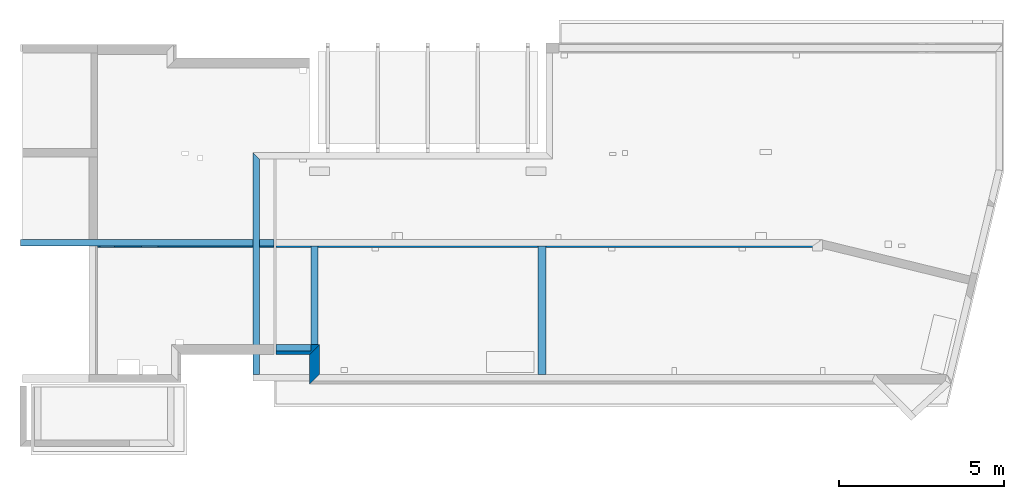
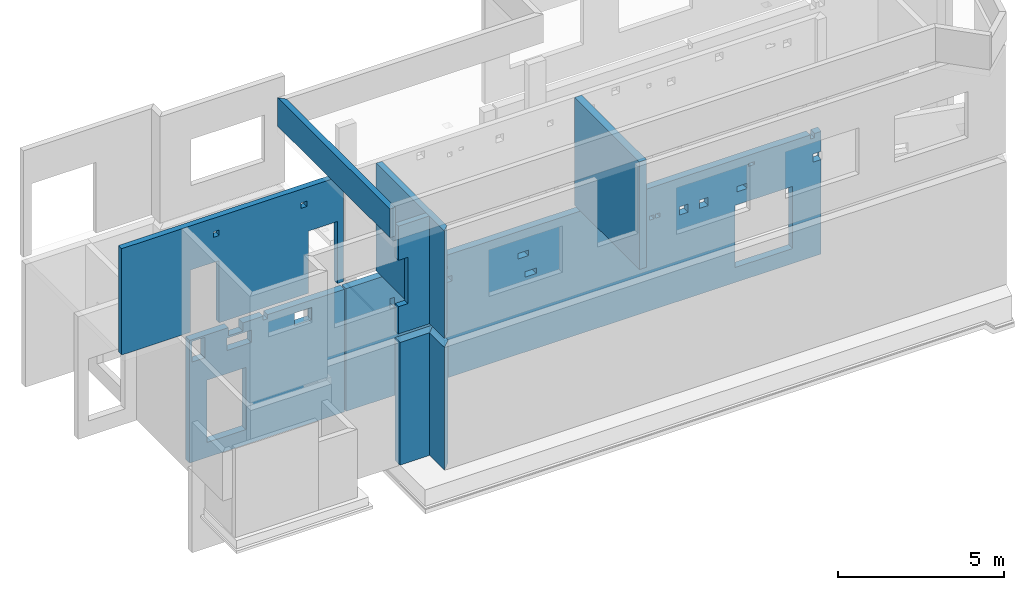
# One storey, part 2 of 7: 9 walls, 30 openings.
"""IFC2X3 building model written with IfcOpenShell, lengths in millimetres."""

from ifc_helpers import new_model, entity, si_unit, converted_unit, derived_unit, money_unit, direction, frame, frame_2d, origin_with_axes, place, context, subcontext, project, spatial, polyline, rectangle, outline, extrude, faceted_brep, material, layer, layer_set, layer_usage, type_object, element, save


model = new_model("IFC2X3")

# Units and contexts
model_context = context("Model", 3, precision=1e-05, world=origin_with_axes(), true_north=direction((0.0, 1.0)))
body_context = subcontext(model_context, "Body", "Model", "MODEL_VIEW", scale=1.0)
ifc_project = project(units=[si_unit("LENGTHUNIT", "METRE", prefix="MILLI"), si_unit("AREAUNIT", "SQUARE_METRE"), si_unit("VOLUMEUNIT", "CUBIC_METRE"), si_unit("ABSORBEDDOSEUNIT", "GRAY"), si_unit("AMOUNTOFSUBSTANCEUNIT", "MOLE"), si_unit("DOSEEQUIVALENTUNIT", "SIEVERT"), si_unit("ELECTRICCAPACITANCEUNIT", "FARAD"), si_unit("ELECTRICCHARGEUNIT", "COULOMB"), si_unit("ELECTRICCONDUCTANCEUNIT", "SIEMENS"), si_unit("ELECTRICCURRENTUNIT", "AMPERE"), si_unit("ELECTRICRESISTANCEUNIT", "OHM"), si_unit("ELECTRICVOLTAGEUNIT", "VOLT"), si_unit("ENERGYUNIT", "JOULE"), si_unit("FORCEUNIT", "NEWTON"), si_unit("FREQUENCYUNIT", "HERTZ"), si_unit("ILLUMINANCEUNIT", "LUX"), si_unit("INDUCTANCEUNIT", "HENRY"), si_unit("LUMINOUSFLUXUNIT", "LUMEN"), si_unit("LUMINOUSINTENSITYUNIT", "CANDELA"), si_unit("MAGNETICFLUXDENSITYUNIT", "TESLA"), si_unit("MAGNETICFLUXUNIT", "WEBER"), si_unit("MASSUNIT", "GRAM"), converted_unit("PLANEANGLEUNIT", "degree", entity("IfcReal", 0.0174532925199433), si_unit("PLANEANGLEUNIT", "RADIAN"), dimensions=[0, 0, 0, 0, 0, 0, 0]), si_unit("POWERUNIT", "WATT"), si_unit("PRESSUREUNIT", "PASCAL"), si_unit("RADIOACTIVITYUNIT", "BECQUEREL"), si_unit("SOLIDANGLEUNIT", "STERADIAN"), si_unit("THERMODYNAMICTEMPERATUREUNIT", "KELVIN"), si_unit("TIMEUNIT", "SECOND"), derived_unit("ACCELERATIONUNIT", [(si_unit("LENGTHUNIT", "METRE", prefix="MILLI"), 1), (si_unit("TIMEUNIT", "SECOND"), -2)]), derived_unit("ANGULARVELOCITYUNIT", [(converted_unit("PLANEANGLEUNIT", "degree", entity("IfcReal", 0.0174532925199433), si_unit("PLANEANGLEUNIT", "RADIAN"), dimensions=[0, 0, 0, 0, 0, 0, 0]), 1), (si_unit("TIMEUNIT", "SECOND"), -1)]), derived_unit("CURVATUREUNIT", [(converted_unit("PLANEANGLEUNIT", "degree", entity("IfcReal", 0.0174532925199433), si_unit("PLANEANGLEUNIT", "RADIAN"), dimensions=[0, 0, 0, 0, 0, 0, 0]), 1), (si_unit("LENGTHUNIT", "METRE", prefix="MILLI"), -1)]), derived_unit("DYNAMICVISCOSITYUNIT", [(si_unit("PRESSUREUNIT", "PASCAL"), 1), (si_unit("TIMEUNIT", "SECOND"), 1)]), derived_unit("HEATFLUXDENSITYUNIT", [(si_unit("POWERUNIT", "WATT"), 1), (si_unit("LENGTHUNIT", "METRE", prefix="MILLI"), -2)]), derived_unit("HEATINGVALUEUNIT", [(si_unit("ENERGYUNIT", "JOULE"), 1), (si_unit("MASSUNIT", "GRAM"), -1)]), derived_unit("INTEGERCOUNTRATEUNIT", [(si_unit("TIMEUNIT", "SECOND"), -1)]), derived_unit("IONCONCENTRATIONUNIT", [(si_unit("MASSUNIT", "GRAM"), 1), (si_unit("VOLUMEUNIT", "CUBIC_METRE"), -1)]), derived_unit("ISOTHERMALMOISTURECAPACITYUNIT", [(si_unit("VOLUMEUNIT", "CUBIC_METRE"), 1), (si_unit("MASSUNIT", "GRAM"), -1)]), derived_unit("KINEMATICVISCOSITYUNIT", [(si_unit("AREAUNIT", "SQUARE_METRE"), 1), (si_unit("TIMEUNIT", "SECOND"), -1)]), derived_unit("LINEARFORCEUNIT", [(si_unit("FORCEUNIT", "NEWTON"), 1), (si_unit("LENGTHUNIT", "METRE", prefix="MILLI"), -1)]), derived_unit("LINEARMOMENTUNIT", [(si_unit("FORCEUNIT", "NEWTON"), 1), (si_unit("LENGTHUNIT", "METRE", prefix="MILLI"), -1)]), derived_unit("LINEARSTIFFNESSUNIT", [(si_unit("FORCEUNIT", "NEWTON"), 1), (si_unit("LENGTHUNIT", "METRE", prefix="MILLI"), -1)]), derived_unit("LINEARVELOCITYUNIT", [(si_unit("LENGTHUNIT", "METRE", prefix="MILLI"), 1), (si_unit("TIMEUNIT", "SECOND"), -1)]), derived_unit("LUMINOUSINTENSITYDISTRIBUTIONUNIT", [(si_unit("LUMINOUSINTENSITYUNIT", "CANDELA"), 1), (si_unit("LUMINOUSFLUXUNIT", "LUMEN"), -1)]), derived_unit("MASSDENSITYUNIT", [(si_unit("MASSUNIT", "GRAM"), 1), (si_unit("VOLUMEUNIT", "CUBIC_METRE"), -1)]), derived_unit("MASSFLOWRATEUNIT", [(si_unit("MASSUNIT", "GRAM"), 1), (si_unit("TIMEUNIT", "SECOND"), -1)]), derived_unit("MASSPERLENGTHUNIT", [(si_unit("MASSUNIT", "GRAM"), 1), (si_unit("LENGTHUNIT", "METRE", prefix="MILLI"), -1)]), derived_unit("MODULUSOFELASTICITYUNIT", [(si_unit("FORCEUNIT", "NEWTON"), 1), (si_unit("AREAUNIT", "SQUARE_METRE"), -1)]), derived_unit("MODULUSOFLINEARSUBGRADEREACTIONUNIT", [(si_unit("FORCEUNIT", "NEWTON"), 1), (si_unit("LENGTHUNIT", "METRE", prefix="MILLI"), -2)]), derived_unit("MODULUSOFROTATIONALSUBGRADEREACTIONUNIT", [(si_unit("FORCEUNIT", "NEWTON"), 1), (si_unit("LENGTHUNIT", "METRE", prefix="MILLI"), 1)]), derived_unit("MODULUSOFSUBGRADEREACTIONUNIT", [(si_unit("FORCEUNIT", "NEWTON"), 1), (si_unit("VOLUMEUNIT", "CUBIC_METRE"), -1)]), derived_unit("MOISTUREDIFFUSIVITYUNIT", [(si_unit("VOLUMEUNIT", "CUBIC_METRE"), 1), (si_unit("TIMEUNIT", "SECOND"), -1)]), derived_unit("MOLECULARWEIGHTUNIT", [(si_unit("MASSUNIT", "GRAM"), 1), (si_unit("AMOUNTOFSUBSTANCEUNIT", "MOLE"), -1)]), derived_unit("PLANARFORCEUNIT", [(si_unit("FORCEUNIT", "NEWTON"), 1), (si_unit("LENGTHUNIT", "METRE", prefix="MILLI"), -2)]), derived_unit("ROTATIONALFREQUENCYUNIT", [(si_unit("TIMEUNIT", "SECOND"), -1)]), derived_unit("ROTATIONALMASSUNIT", [(si_unit("MASSUNIT", "GRAM"), 1), (si_unit("LENGTHUNIT", "METRE", prefix="MILLI"), 2)]), derived_unit("ROTATIONALSTIFFNESSUNIT", [(si_unit("FORCEUNIT", "NEWTON"), 1), (si_unit("LENGTHUNIT", "METRE", prefix="MILLI"), 1), (converted_unit("PLANEANGLEUNIT", "degree", entity("IfcReal", 0.0174532925199433), si_unit("PLANEANGLEUNIT", "RADIAN"), dimensions=[0, 0, 0, 0, 0, 0, 0]), -1)]), derived_unit("SECTIONAREAINTEGRALUNIT", [(si_unit("LENGTHUNIT", "METRE", prefix="MILLI"), 5)]), derived_unit("SECTIONMODULUSUNIT", [(si_unit("LENGTHUNIT", "METRE", prefix="MILLI"), 3)]), derived_unit("SHEARMODULUSUNIT", [(si_unit("FORCEUNIT", "NEWTON"), 1), (si_unit("AREAUNIT", "SQUARE_METRE"), -1)]), derived_unit("SOUNDPOWERUNIT", [(si_unit("ENERGYUNIT", "JOULE"), 1), (si_unit("TIMEUNIT", "SECOND"), -1)]), derived_unit("SPECIFICHEATCAPACITYUNIT", [(si_unit("FORCEUNIT", "NEWTON"), 1), (si_unit("MASSUNIT", "GRAM"), -1), (si_unit("THERMODYNAMICTEMPERATUREUNIT", "KELVIN"), -1)]), derived_unit("TEMPERATUREGRADIENTUNIT", [(si_unit("THERMODYNAMICTEMPERATUREUNIT", "KELVIN"), 1), (si_unit("LENGTHUNIT", "METRE", prefix="MILLI"), -1)]), derived_unit("THERMALADMITTANCEUNIT", [(si_unit("POWERUNIT", "WATT"), 1), (si_unit("AREAUNIT", "SQUARE_METRE"), -1), (si_unit("THERMODYNAMICTEMPERATUREUNIT", "KELVIN"), -1)]), derived_unit("THERMALCONDUCTANCEUNIT", [(si_unit("POWERUNIT", "WATT"), 1), (si_unit("LENGTHUNIT", "METRE", prefix="MILLI"), -1), (si_unit("THERMODYNAMICTEMPERATUREUNIT", "KELVIN"), -1)]), derived_unit("THERMALEXPANSIONCOEFFICIENTUNIT", [(si_unit("THERMODYNAMICTEMPERATUREUNIT", "KELVIN"), -1)]), derived_unit("THERMALRESISTANCEUNIT", [(si_unit("AREAUNIT", "SQUARE_METRE"), 1), (si_unit("POWERUNIT", "WATT"), -1)]), derived_unit("THERMALTRANSMITTANCEUNIT", [(si_unit("POWERUNIT", "WATT"), 1), (si_unit("AREAUNIT", "SQUARE_METRE"), -1), (si_unit("THERMODYNAMICTEMPERATUREUNIT", "KELVIN"), -1)]), derived_unit("TORQUEUNIT", [(si_unit("FORCEUNIT", "NEWTON"), 1), (si_unit("LENGTHUNIT", "METRE", prefix="MILLI"), 1)]), derived_unit("VAPORPERMEABILITYUNIT", [(si_unit("MASSUNIT", "GRAM"), 1), (si_unit("TIMEUNIT", "SECOND"), -1)]), derived_unit("VOLUMETRICFLOWRATEUNIT", [(si_unit("VOLUMEUNIT", "CUBIC_METRE"), 1), (si_unit("TIMEUNIT", "SECOND"), -1)]), derived_unit("WARPINGCONSTANTUNIT", [(si_unit("LENGTHUNIT", "METRE", prefix="MILLI"), 6)]), derived_unit("WARPINGMOMENTUNIT", [(si_unit("FORCEUNIT", "NEWTON"), 1), (si_unit("LENGTHUNIT", "METRE", prefix="MILLI"), 2)]), money_unit("USD")], contexts=[model_context])

# Site, building, storey
site_placement = place(None, origin_with_axes())
site = spatial("IfcSite", under=ifc_project, at=site_placement, CompositionType="ELEMENT")
building_placement = place(site_placement, origin_with_axes())
building = spatial("IfcBuilding", under=site, at=building_placement, Name="1", CompositionType="ELEMENT")
storey_placement = place(building_placement, frame((0.0, 0.0, -4900.0), z_axis=(0.0, 0.0, 1.0), x_axis=(1.0, 0.0, 0.0)))
storey = spatial("IfcBuildingStorey", under=building, at=storey_placement, CompositionType="ELEMENT", Elevation=-4900.0)

# Wall, openings
ifc_material = material()
ifc_layer_1 = layer(ifc_material, 250.0, ventilated=False)
ifc_layer_set_1 = layer_set([ifc_layer_1])
ifc_layer_usage_1 = layer_usage(ifc_layer_set_1, "AXIS2", "POSITIVE", 0.0)
wall_type = type_object("IfcWallType", PredefinedType="NOTDEFINED")
wall_1_placement = place(storey_placement, frame((2530.0, 3850.0, 0.0), z_axis=(0.0, 0.0, 1.0), x_axis=(1.0, 0.0, 0.0)))
wall_1 = element("IfcWallStandardCase", 1, at=wall_1_placement, inside=storey, type_object=wall_type, material=ifc_layer_usage_1, context=body_context, shape_type="SweptSolid", body=[
    extrude(rectangle(XDim=5370.0, YDim=250.0, at=frame_2d((2685.0, 125.0), x_axis=(1.0, 0.0))), origin_with_axes(), (0.0, 0.0, 1.0), 4500.0),
])
opening_1_placement = place(wall_1_placement, frame((600.0, 0.0, 550.0), z_axis=(0.0, 0.0, 1.0), x_axis=(1.0, 0.0, 0.0)))
element("IfcOpeningElement", 2, at=opening_1_placement, cuts=wall_1, ObjectType="Opening", context=body_context, shape_type="SweptSolid", body=[
    extrude(rectangle(XDim=2280.0, YDim=1350.0, at=frame_2d((-675.0, 1140.0), x_axis=(0.0, -1.0))), frame((0.0, 0.0, 0.0), z_axis=(0.0, 1.0, 0.0), x_axis=(-1.0, 0.0, 0.0)), (0.0, 0.0, 1.0), 250.0),
])
opening_2_placement = place(wall_1_placement, frame((75.0, 0.0, 3680.0), z_axis=(0.0, 0.0, 1.0), x_axis=(1.0, 0.0, 0.0)))
element("IfcOpeningElement", 3, at=opening_2_placement, cuts=wall_1, ObjectType="Opening", context=body_context, shape_type="SweptSolid", body=[
    extrude(rectangle(XDim=750.0, YDim=450.0, at=frame_2d((-225.0, 375.0), x_axis=(0.0, -1.0))), frame((0.0, 0.0, 0.0), z_axis=(0.0, 1.0, 0.0), x_axis=(-1.0, 0.0, 0.0)), (0.0, 0.0, 1.0), 250.0),
])
opening_3_placement = place(wall_1_placement, frame((1290.0, 0.0, 3680.0), z_axis=(0.0, 0.0, 1.0), x_axis=(1.0, 0.0, 0.0)))
element("IfcOpeningElement", 4, at=opening_3_placement, cuts=wall_1, ObjectType="Opening", context=body_context, shape_type="SweptSolid", body=[
    extrude(rectangle(XDim=450.0, YDim=850.0, at=frame_2d((-425.0, 225.0), x_axis=(0.0, -1.0))), frame((0.0, 0.0, 0.0), z_axis=(0.0, 1.0, 0.0), x_axis=(-1.0, 0.0, 0.0)), (0.0, 0.0, 1.0), 250.0),
])
opening_4_placement = place(wall_1_placement, frame((1340.0, 0.0, 4200.0), z_axis=(0.0, 0.0, 1.0), x_axis=(1.0, 0.0, 0.0)))
element("IfcOpeningElement", 5, at=opening_4_placement, cuts=wall_1, ObjectType="Opening", context=body_context, shape_type="SweptSolid", body=[
    extrude(rectangle(XDim=300.0, YDim=500.0, at=frame_2d((-250.0, 150.0), x_axis=(0.0, -1.0))), frame((0.0, 0.0, 0.0), z_axis=(0.0, 1.0, 0.0), x_axis=(-1.0, 0.0, 0.0)), (0.0, 0.0, 1.0), 250.0),
])
opening_5_placement = place(wall_1_placement, frame((2550.000072, 0.0, 4350.0), z_axis=(0.0, 0.0, 1.0), x_axis=(1.0, 0.0, 0.0)))
element("IfcOpeningElement", 6, at=opening_5_placement, cuts=wall_1, ObjectType="Opening", context=body_context, shape_type="SweptSolid", body=[
    extrude(rectangle(XDim=150.0, YDim=150.0, at=frame_2d((-75.0, 75.0), x_axis=(0.0, -1.0))), frame((0.0, 0.0, 0.0), z_axis=(0.0, 1.0, 0.0), x_axis=(-1.0, 0.0, 0.0)), (0.0, 0.0, 1.0), 250.0),
])
opening_6_placement = place(wall_1_placement, frame((3629.999861, 0.0, 3780.0), z_axis=(0.0, 0.0, 1.0), x_axis=(1.0, 0.0, 0.0)))
element("IfcOpeningElement", 7, at=opening_6_placement, cuts=wall_1, ObjectType="Opening", context=body_context, shape_type="SweptSolid", body=[
    extrude(rectangle(XDim=450.0, YDim=600.0, at=frame_2d((-300.0, 225.0), x_axis=(0.0, -1.0))), frame((0.0, 0.0, 0.0), z_axis=(0.0, 1.0, 0.0), x_axis=(-1.0, 0.0, 0.0)), (0.0, 0.0, 1.0), 250.0),
])

wall_2_placement = place(storey_placement, frame((7950.0, 3850.0, 0.0), z_axis=(0.0, 0.0, 1.0), x_axis=(1.0, 0.0, 0.0)))
wall_2 = element("IfcWallStandardCase", 8, at=wall_2_placement, inside=storey, type_object=wall_type, material=ifc_layer_usage_1, context=body_context, shape_type="SweptSolid", body=[
    extrude(outline(polyline([(16515.0, 250.0), (0.0, 250.0), (0.0, 0.0), (16484.990959, 0.0), (16515.0, 250.0)])), origin_with_axes(), (0.0, 0.0, 1.0), 4500.0),
])
opening_7_placement = place(wall_2_placement, frame((13495.0, 0.0, 550.0), z_axis=(0.0, 0.0, 1.0), x_axis=(1.0, 0.0, 0.0)))
element("IfcOpeningElement", 9, at=opening_7_placement, cuts=wall_2, ObjectType="Opening", context=body_context, shape_type="SweptSolid", body=[
    extrude(rectangle(XDim=2280.0, YDim=2000.0, at=frame_2d((-1000.0, 1140.0), x_axis=(0.0, -1.0))), frame((0.0, 0.0, 0.0), z_axis=(0.0, 1.0, 0.0), x_axis=(-1.0, 0.0, 0.0)), (0.0, 0.0, 1.0), 250.0),
])
opening_8_placement = place(wall_2_placement, frame((1525.0, 0.0, 3240.0), z_axis=(0.0, 0.0, 1.0), x_axis=(1.0, 0.0, 0.0)))
element("IfcOpeningElement", 10, at=opening_8_placement, cuts=wall_2, ObjectType="Opening", context=body_context, shape_type="SweptSolid", body=[
    extrude(rectangle(XDim=360.0, YDim=150.0, at=frame_2d((-75.0, 180.0), x_axis=(0.0, -1.0))), frame((0.0, 0.0, 0.0), z_axis=(0.0, 1.0, 0.0), x_axis=(-1.0, 0.0, 0.0)), (0.0, 0.0, 1.0), 250.0),
])
opening_9_placement = place(wall_2_placement, frame((3025.0, 0.0, 3500.0), z_axis=(0.0, 0.0, 1.0), x_axis=(1.0, 0.0, 0.0)))
element("IfcOpeningElement", 11, at=opening_9_placement, cuts=wall_2, ObjectType="Opening", context=body_context, shape_type="SweptSolid", body=[
    extrude(rectangle(XDim=200.0, YDim=200.0, at=frame_2d((-100.0, 100.0), x_axis=(0.0, -1.0))), frame((0.0, 0.0, 0.0), z_axis=(0.0, 1.0, 0.0), x_axis=(-1.0, 0.0, 0.0)), (0.0, 0.0, 1.0), 250.0),
])
opening_10_placement = place(wall_2_placement, frame((3475.0, 0.0, 3500.0), z_axis=(0.0, 0.0, 1.0), x_axis=(1.0, 0.0, 0.0)))
element("IfcOpeningElement", 12, at=opening_10_placement, cuts=wall_2, ObjectType="Opening", context=body_context, shape_type="SweptSolid", body=[
    extrude(rectangle(XDim=200.0, YDim=200.0, at=frame_2d((-100.0, 100.0), x_axis=(0.0, -1.0))), frame((0.0, 0.0, 0.0), z_axis=(0.0, 1.0, 0.0), x_axis=(-1.0, 0.0, 0.0)), (0.0, 0.0, 1.0), 250.0),
])
opening_11_placement = place(wall_2_placement, frame((5975.0, 0.0, 3500.0), z_axis=(0.0, 0.0, 1.0), x_axis=(1.0, 0.0, 0.0)))
element("IfcOpeningElement", 13, at=opening_11_placement, cuts=wall_2, ObjectType="Opening", context=body_context, shape_type="SweptSolid", body=[
    extrude(rectangle(XDim=200.0, YDim=350.0, at=frame_2d((-175.0, 100.0), x_axis=(0.0, -1.0))), frame((0.0, 0.0, 0.0), z_axis=(0.0, 1.0, 0.0), x_axis=(-1.0, 0.0, 0.0)), (0.0, 0.0, 1.0), 250.0),
])
opening_12_placement = place(wall_2_placement, frame((3315.0, 0.0, 4000.0), z_axis=(0.0, 0.0, 1.0), x_axis=(1.0, 0.0, 0.0)))
element("IfcOpeningElement", 14, at=opening_12_placement, cuts=wall_2, ObjectType="Opening", context=body_context, shape_type="SweptSolid", body=[
    extrude(rectangle(XDim=100.0, YDim=200.0, at=frame_2d((-100.0, 50.0), x_axis=(0.0, -1.0))), frame((0.0, 0.0, 0.0), z_axis=(0.0, 1.0, 0.0), x_axis=(-1.0, 0.0, 0.0)), (0.0, 0.0, 1.0), 250.0),
])
opening_13_placement = place(wall_2_placement, frame((6205.0, 0.0, 2750.0), z_axis=(0.0, 0.0, 1.0), x_axis=(1.0, 0.0, 0.0)))
element("IfcOpeningElement", 15, at=opening_13_placement, cuts=wall_2, ObjectType="Opening", context=body_context, shape_type="SweptSolid", body=[
    extrude(rectangle(XDim=200.0, YDim=400.0, at=frame_2d((-200.0, 100.0), x_axis=(0.0, -1.0))), frame((0.0, 0.0, 0.0), z_axis=(0.0, 1.0, 0.0), x_axis=(-1.0, 0.0, 0.0)), (0.0, 0.0, 1.0), 250.0),
])
opening_14_placement = place(wall_2_placement, frame((9635.0, 0.0, 3300.0), z_axis=(0.0, 0.0, 1.0), x_axis=(1.0, 0.0, 0.0)))
element("IfcOpeningElement", 16, at=opening_14_placement, cuts=wall_2, ObjectType="Opening", context=body_context, shape_type="SweptSolid", body=[
    extrude(rectangle(XDim=200.0, YDim=200.0, at=frame_2d((-100.0, 100.0), x_axis=(0.0, -1.0))), frame((0.0, 0.0, 0.0), z_axis=(0.0, 1.0, 0.0), x_axis=(-1.0, 0.0, 0.0)), (0.0, 0.0, 1.0), 250.0),
])
opening_15_placement = place(wall_2_placement, frame((9985.0, 0.0, 3300.0), z_axis=(0.0, 0.0, 1.0), x_axis=(1.0, 0.0, 0.0)))
element("IfcOpeningElement", 17, at=opening_15_placement, cuts=wall_2, ObjectType="Opening", context=body_context, shape_type="SweptSolid", body=[
    extrude(rectangle(XDim=200.0, YDim=200.0, at=frame_2d((-100.0, 100.0), x_axis=(0.0, -1.0))), frame((0.0, 0.0, 0.0), z_axis=(0.0, 1.0, 0.0), x_axis=(-1.0, 0.0, 0.0)), (0.0, 0.0, 1.0), 250.0),
])
opening_16_placement = place(wall_2_placement, frame((10535.0, 0.0, 3325.0), z_axis=(0.0, 0.0, 1.0), x_axis=(1.0, 0.0, 0.0)))
element("IfcOpeningElement", 18, at=opening_16_placement, cuts=wall_2, ObjectType="Opening", context=body_context, shape_type="SweptSolid", body=[
    extrude(rectangle(XDim=150.0, YDim=150.0, at=frame_2d((-75.0, 75.0), x_axis=(0.0, -1.0))), frame((0.0, 0.0, 0.0), z_axis=(0.0, 1.0, 0.0), x_axis=(-1.0, 0.0, 0.0)), (0.0, 0.0, 1.0), 250.0),
])
opening_17_placement = place(wall_2_placement, frame((10745.0, 0.0, 3325.0), z_axis=(0.0, 0.0, 1.0), x_axis=(1.0, 0.0, 0.0)))
element("IfcOpeningElement", 19, at=opening_17_placement, cuts=wall_2, ObjectType="Opening", context=body_context, shape_type="SweptSolid", body=[
    extrude(rectangle(XDim=150.0, YDim=150.0, at=frame_2d((-75.0, 75.0), x_axis=(0.0, -1.0))), frame((0.0, 0.0, 0.0), z_axis=(0.0, 1.0, 0.0), x_axis=(-1.0, 0.0, 0.0)), (0.0, 0.0, 1.0), 250.0),
])
opening_18_placement = place(wall_2_placement, frame((11565.0, 0.0, 3150.0), z_axis=(0.0, 0.0, 1.0), x_axis=(1.0, 0.0, 0.0)))
element("IfcOpeningElement", 20, at=opening_18_placement, cuts=wall_2, ObjectType="Opening", context=body_context, shape_type="SweptSolid", body=[
    extrude(rectangle(XDim=300.0, YDim=300.0, at=frame_2d((-150.0, 150.0), x_axis=(0.0, -1.0))), frame((0.0, 0.0, 0.0), z_axis=(0.0, 1.0, 0.0), x_axis=(-1.0, 0.0, 0.0)), (0.0, 0.0, 1.0), 250.0),
])
opening_19_placement = place(wall_2_placement, frame((12265.0, 0.0, 3150.0), z_axis=(0.0, 0.0, 1.0), x_axis=(1.0, 0.0, 0.0)))
element("IfcOpeningElement", 21, at=opening_19_placement, cuts=wall_2, ObjectType="Opening", context=body_context, shape_type="SweptSolid", body=[
    extrude(rectangle(XDim=300.0, YDim=300.0, at=frame_2d((-150.0, 150.0), x_axis=(0.0, -1.0))), frame((0.0, 0.0, 0.0), z_axis=(0.0, 1.0, 0.0), x_axis=(-1.0, 0.0, 0.0)), (0.0, 0.0, 1.0), 250.0),
])
opening_20_placement = place(wall_2_placement, frame((13565.0, 0.0, 3300.0), z_axis=(0.0, 0.0, 1.0), x_axis=(1.0, 0.0, 0.0)))
element("IfcOpeningElement", 22, at=opening_20_placement, cuts=wall_2, ObjectType="Opening", context=body_context, shape_type="SweptSolid", body=[
    extrude(rectangle(XDim=200.0, YDim=350.0, at=frame_2d((-175.0, 100.0), x_axis=(0.0, -1.0))), frame((0.0, 0.0, 0.0), z_axis=(0.0, 1.0, 0.0), x_axis=(-1.0, 0.0, 0.0)), (0.0, 0.0, 1.0), 250.0),
])
opening_21_placement = place(wall_2_placement, frame((16205.0, 0.0, 3465.0), z_axis=(0.0, 0.0, 1.0), x_axis=(1.0, 0.0, 0.0)))
element("IfcOpeningElement", 23, at=opening_21_placement, cuts=wall_2, ObjectType="Opening", context=body_context, shape_type="SweptSolid", body=[
    extrude(rectangle(XDim=300.0, YDim=300.0, at=frame_2d((-150.0, 150.0), x_axis=(0.0, -1.0))), frame((0.0, 0.0, 0.0), z_axis=(0.0, 1.0, 0.0), x_axis=(-1.0, 0.0, 0.0)), (0.0, 0.0, 1.0), 250.0),
])
opening_22_placement = place(wall_2_placement, frame((9549.956428, 0.0, 2950.0), z_axis=(0.0, 0.0, 1.0), x_axis=(1.0, 0.0, 0.0)))
element("IfcOpeningElement", 24, at=opening_22_placement, cuts=wall_2, ObjectType="Opening", context=body_context, shape_type="SweptSolid", body=[
    extrude(rectangle(XDim=200.0, YDim=400.0, at=frame_2d((-200.0, 100.0), x_axis=(0.0, -1.0))), frame((0.0, 0.0, 0.0), z_axis=(0.0, 1.0, 0.0), x_axis=(-1.0, 0.0, 0.0)), (0.0, 0.0, 1.0), 250.0),
])
opening_23_placement = place(wall_2_placement, frame((10079.956428, 0.0, 4100.0), z_axis=(0.0, 0.0, 1.0), x_axis=(1.0, 0.0, 0.0)))
element("IfcOpeningElement", 25, at=opening_23_placement, cuts=wall_2, ObjectType="Opening", context=body_context, shape_type="SweptSolid", body=[
    extrude(rectangle(XDim=100.0, YDim=200.0, at=frame_2d((-100.0, 50.0), x_axis=(0.0, -1.0))), frame((0.0, 0.0, 0.0), z_axis=(0.0, 1.0, 0.0), x_axis=(-1.0, 0.0, 0.0)), (0.0, 0.0, 1.0), 250.0),
])
opening_24_placement = place(wall_2_placement, frame((13965.0, 0.0, 4100.0), z_axis=(0.0, 0.0, 1.0), x_axis=(1.0, 0.0, 0.0)))
element("IfcOpeningElement", 26, at=opening_24_placement, cuts=wall_2, ObjectType="Opening", context=body_context, shape_type="SweptSolid", body=[
    extrude(rectangle(XDim=100.0, YDim=200.0, at=frame_2d((-100.0, 50.0), x_axis=(0.0, -1.0))), frame((0.0, 0.0, 0.0), z_axis=(0.0, 1.0, 0.0), x_axis=(-1.0, 0.0, 0.0)), (0.0, 0.0, 1.0), 250.0),
])
opening_25_placement = place(wall_2_placement, frame((16105.0, 0.0, 4350.0), z_axis=(0.0, 0.0, 1.0), x_axis=(1.0, 0.0, 0.0)))
element("IfcOpeningElement", 27, at=opening_25_placement, cuts=wall_2, ObjectType="Opening", context=body_context, shape_type="SweptSolid", body=[
    extrude(rectangle(XDim=150.0, YDim=150.0, at=frame_2d((-75.0, 75.0), x_axis=(0.0, -1.0))), frame((0.0, 0.0, 0.0), z_axis=(0.0, 1.0, 0.0), x_axis=(-1.0, 0.0, 0.0)), (0.0, 0.0, 1.0), 250.0),
])

# Walls
ifc_layer_2 = layer(ifc_material, 300.0, ventilated=False)
ifc_layer_set_2 = layer_set([ifc_layer_2])
ifc_layer_usage_2 = layer_usage(ifc_layer_set_2, "AXIS2", "POSITIVE", 0.0)
wall_3_placement = place(storey_placement, frame((7950.0, 600.0, 0.0), z_axis=(0.0, 0.0, 1.0), x_axis=(1.0, 0.0, 0.0)))
element("IfcWallStandardCase", 28, at=wall_3_placement, inside=storey, type_object=wall_type, material=ifc_layer_usage_2, context=body_context, shape_type="SweptSolid", body=[
    extrude(outline(polyline([(1325.0, 300.0), (0.0, 300.0), (0.0, 0.0), (1025.0, 0.0), (1325.0, 300.0)])), origin_with_axes(), (0.0, 0.0, 1.0), 4500.0),
])
wall_4_placement = place(storey_placement, frame((8975.0, 600.0, 0.0), z_axis=(0.0, 0.0, 1.0), x_axis=(0.0, -1.0, 0.0)))
element("IfcWallStandardCase", 29, at=wall_4_placement, inside=storey, type_object=wall_type, material=ifc_layer_usage_2, context=body_context, shape_type="SweptSolid", body=[
    extrude(outline(polyline([(600.0, 300.0), (-300.0, 300.0), (0.0, 0.0), (900.0, 0.0), (600.0, 300.0)])), origin_with_axes(), (0.0, 0.0, 1.0), 4500.0),
])
wall_5_placement = place(storey_placement, frame((15905.0, 0.0, 4750.0), z_axis=(0.0, 0.0, 1.0), x_axis=(0.0, 1.0, 0.0)))
element("IfcWallStandardCase", 30, at=wall_5_placement, inside=storey, type_object=wall_type, material=ifc_layer_usage_1, context=body_context, shape_type="SweptSolid", body=[
    extrude(rectangle(XDim=3900.0, YDim=250.0, at=frame_2d((1950.0, -125.0), x_axis=(1.0, 0.0))), origin_with_axes(), (0.0, 0.0, 1.0), 3950.0),
])
ifc_layer_3 = layer(ifc_material, 200.0, ventilated=False)
ifc_layer_set_3 = layer_set([ifc_layer_3])
ifc_layer_usage_3 = layer_usage(ifc_layer_set_3, "AXIS2", "POSITIVE", 0.0)
wall_6_placement = place(storey_placement, frame((9025.0, -200.0, 4750.0), z_axis=(0.0, 0.0, 1.0), x_axis=(0.0, 1.0, 0.0)))
element("IfcWallStandardCase", 31, at=wall_6_placement, inside=storey, type_object=wall_type, material=ifc_layer_usage_3, context=body_context, shape_type="SweptSolid", body=[
    extrude(outline(polyline([(0.0, 0.0), (200.0, -200.0), (4100.0, -200.0), (4100.0, 0.0), (0.0, 0.0)])), origin_with_axes(), (0.0, 0.0, 1.0), 3950.0),
])

# Wall, opening
wall_7_placement = place(storey_placement, frame((7950.0, 700.0, 4750.0), z_axis=(0.0, 0.0, 1.0), x_axis=(1.0, 0.0, 0.0)))
wall_7 = element("IfcWallStandardCase", 32, at=wall_7_placement, inside=storey, type_object=wall_type, material=ifc_layer_usage_3, context=body_context, shape_type="SweptSolid", body=[
    extrude(rectangle(XDim=1075.0, YDim=200.0, at=frame_2d((537.5, 100.0), x_axis=(-1.0, 0.0))), origin_with_axes(), (0.0, 0.0, 1.0), 3950.0),
])
opening_26_placement = place(wall_7_placement, frame((0.0, 0.0, 1000.0), z_axis=(0.0, 0.0, 1.0), x_axis=(1.0, 0.0, 0.0)))
element("IfcOpeningElement", 33, at=opening_26_placement, cuts=wall_7, ObjectType="Opening", context=body_context, shape_type="Brep", body=[
    faceted_brep([(325.000326, 200.0, 0.0), (0.0, 200.0, 0.0), (0.0, 200.0, 1700.0), (325.000326, 200.0, 1700.0), (0.0, 0.0, 0.0), (0.0, 0.0, 1700.0), (325.0, 0.0, 0.0), (325.0, 0.0, 1700.0)], [[[0, 1, 2, 3]], [[1, 4, 5, 2]], [[4, 6, 7, 5]], [[1, 0, 6, 4]], [[3, 7, 6, 0]], [[5, 7, 3, 2]]]),
])

# Wall, openings
wall_8_placement = place(storey_placement, frame((200.0, 3900.0, 4750.0), z_axis=(0.0, 0.0, 1.0), x_axis=(1.0, 0.0, 0.0)))
wall_8 = element("IfcWallStandardCase", 34, at=wall_8_placement, inside=storey, type_object=wall_type, material=ifc_layer_usage_3, context=body_context, shape_type="SweptSolid", body=[
    extrude(rectangle(XDim=7700.0, YDim=200.0, at=frame_2d((3850.0, 100.0), x_axis=(1.0, 0.0))), origin_with_axes(), (0.0, 0.0, 1.0), 3900.0),
])
opening_27_placement = place(wall_8_placement, frame((2380.0, 0.0, 0.0), z_axis=(0.0, 0.0, 1.0), x_axis=(1.0, 0.0, 0.0)))
element("IfcOpeningElement", 35, at=opening_27_placement, cuts=wall_8, ObjectType="Opening", context=body_context, shape_type="SweptSolid", body=[
    extrude(rectangle(XDim=2280.0, YDim=1000.0, at=frame_2d((-500.0, 1140.0), x_axis=(0.0, -1.0))), frame((0.0, 0.0, 0.0), z_axis=(0.0, 1.0, 0.0), x_axis=(-1.0, 0.0, 0.0)), (0.0, 0.0, 1.0), 200.0),
])
opening_28_placement = place(wall_8_placement, frame((6485.0, 0.0, 0.0), z_axis=(0.0, 0.0, 1.0), x_axis=(1.0, 0.0, 0.0)))
element("IfcOpeningElement", 36, at=opening_28_placement, cuts=wall_8, ObjectType="Opening", context=body_context, shape_type="SweptSolid", body=[
    extrude(rectangle(XDim=2280.0, YDim=1000.0, at=frame_2d((-500.0, 1140.0), x_axis=(0.0, -1.0))), frame((0.0, 0.0, 0.0), z_axis=(0.0, 1.0, 0.0), x_axis=(-1.0, 0.0, 0.0)), (0.0, 0.0, 1.0), 200.0),
])
opening_29_placement = place(wall_8_placement, frame((3180.0, 0.0, 3200.0), z_axis=(0.0, 0.0, 1.0), x_axis=(1.0, 0.0, 0.0)))
element("IfcOpeningElement", 37, at=opening_29_placement, cuts=wall_8, ObjectType="Opening", context=body_context, shape_type="SweptSolid", body=[
    extrude(rectangle(XDim=200.0, YDim=200.0, at=frame_2d((-100.0, 100.0), x_axis=(0.0, -1.0))), frame((0.0, 0.0, 0.0), z_axis=(0.0, 1.0, 0.0), x_axis=(-1.0, 0.0, 0.0)), (0.0, 0.0, 1.0), 200.0),
])
opening_30_placement = place(wall_8_placement, frame((6225.0, 0.0, 3200.0), z_axis=(0.0, 0.0, 1.0), x_axis=(1.0, 0.0, 0.0)))
element("IfcOpeningElement", 38, at=opening_30_placement, cuts=wall_8, ObjectType="Opening", context=body_context, shape_type="SweptSolid", body=[
    extrude(rectangle(XDim=200.0, YDim=200.0, at=frame_2d((-100.0, 100.0), x_axis=(0.0, -1.0))), frame((0.0, 0.0, 0.0), z_axis=(0.0, 1.0, 0.0), x_axis=(-1.0, 0.0, 0.0)), (0.0, 0.0, 1.0), 200.0),
])

# Wall
wall_9_placement = place(storey_placement, frame((7250.0, 0.0, 8950.0), z_axis=(0.0, 0.0, 1.0), x_axis=(0.0, 1.0, 0.0)))
element("IfcWallStandardCase", 39, at=wall_9_placement, inside=storey, type_object=wall_type, material=ifc_layer_usage_3, context=body_context, shape_type="SweptSolid", body=[
    extrude(outline(polyline([(6740.0, 0.0), (0.0, 0.0), (0.0, -200.0), (6540.0, -200.0), (6740.0, 0.0)])), origin_with_axes(), (0.0, 0.0, 1.0), 1050.0),
])

save(model, "model.ifc")
